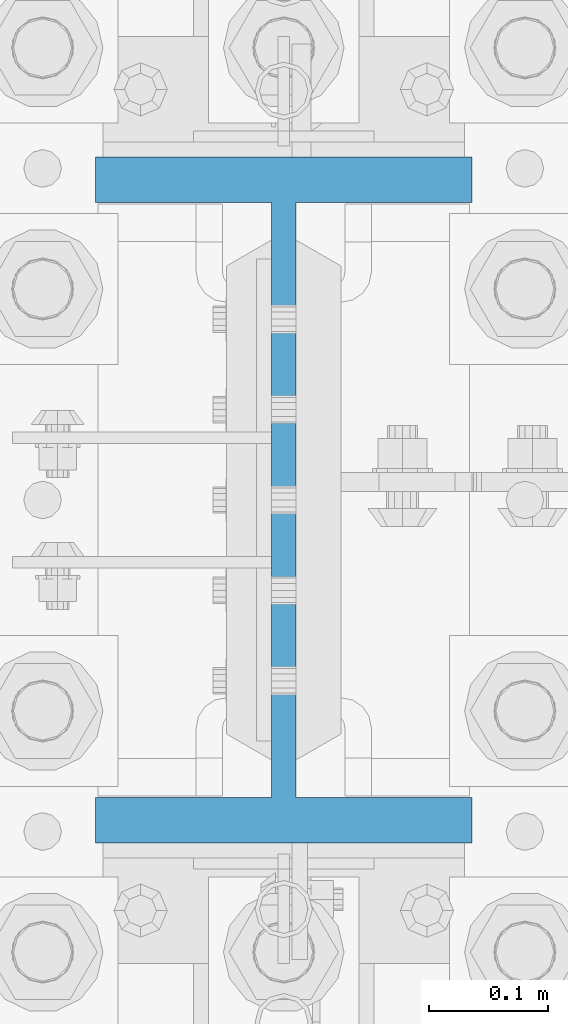
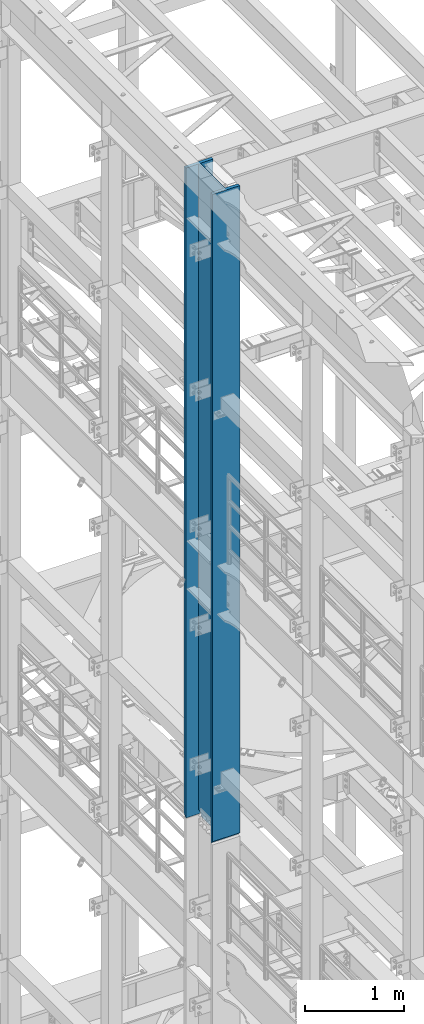
# One storey, part 730 of 1876: 1 column, 1 element without a shape of its own.
"""IFC2X3 building model written with IfcOpenShell, lengths in millimetres."""

from ifc_helpers import new_model, si_unit, frame, origin_with_axes, place, context, subcontext, project, spatial, faceted_brep, material, type_object, element, aggregate, save


model = new_model("IFC2X3")

# Units and contexts
model_context = context("Model", 3, precision=1e-05, world=origin_with_axes())
body_context = subcontext(model_context, "Body", "Model", "MODEL_VIEW")
ifc_project = project(units=[si_unit("LENGTHUNIT", "METRE", prefix="MILLI"), si_unit("AREAUNIT", "SQUARE_METRE"), si_unit("VOLUMEUNIT", "CUBIC_METRE"), si_unit("MASSUNIT", "GRAM", prefix="KILO"), si_unit("TIMEUNIT", "SECOND"), si_unit("PLANEANGLEUNIT", "RADIAN"), si_unit("SOLIDANGLEUNIT", "STERADIAN"), si_unit("THERMODYNAMICTEMPERATUREUNIT", "DEGREE_CELSIUS"), si_unit("LUMINOUSINTENSITYUNIT", "LUMEN")], contexts=[model_context])

# Site, building, storey
site_placement = place(None, origin_with_axes())
site = spatial("IfcSite", under=ifc_project, at=site_placement, CompositionType="ELEMENT")
building_placement = place(site_placement, origin_with_axes())
building = spatial("IfcBuilding", under=site, at=building_placement, Name="Undefined", CompositionType="ELEMENT")
storey_placement = place(building_placement, origin_with_axes())
storey = spatial("IfcBuildingStorey", under=building, at=storey_placement, Name="Undefined", CompositionType="ELEMENT", Elevation=0.0)

# Assembly, column
assembly_placement = place(storey_placement, origin_with_axes())
assembly = element("IfcElementAssembly", 1, at=assembly_placement, inside=storey, Name="COLUMN", AssemblyPlace="NOTDEFINED", PredefinedType="RIGID_FRAME")
ifc_material = material(Name="STEEL/A992")
column_type = type_object("IfcColumnType", Name="W21X182", PredefinedType="NOTDEFINED")
column_placement = place(assembly_placement, frame((0.0, 7620.0, 14528.8), z_axis=(0.0, 1.0, 0.0), x_axis=(0.0, 0.0, 1.0)))
column = element("IfcColumn", 2, at=column_placement, type_object=column_type, material=ifc_material, Name="COLUMN", ObjectType="W21X182", context=body_context, shape_type="Brep", body=[
    faceted_brep([(23.8124996185306, 10.31875, 203.498507902428), (23.8124996185306, 10.31875, -203.49850776611), (6.35000000000036, -7.14374961853027, -200.025000762939), (6.35000000000036, -7.14374961853027, 200.025000762939), (8026.4, 158.75, -288.925), (8026.4, -158.75, -288.925), (41.2749999999833, -158.75, -288.925), (41.2749999999833, 158.75, -288.925), (8026.4, -158.75, -250.825), (57.149999999996, -158.75, -250.825), (6.35000000000036, -158.75, -250.825), (6.35000000000036, -158.75, -254.000000000019), (57.149999999996, -10.3187500000004, -250.825), (6.35000000000036, -10.3187500000004, -250.825), (8026.4, -10.3187500000004, -250.825), (6.35000000000036, -158.75, 250.825), (57.1499992370573, -158.75, 250.825), (8026.4, -158.75, 250.825), (8026.4, -158.75, 288.925), (41.2749999999833, -158.75, 288.925), (6.35000000000036, -158.75, 254.00000000002), (8026.4, 158.75, 288.925), (41.2749999999833, 158.75, 288.925), (6.35000000000036, 158.75, 254.00000000002), (8026.4, 158.75, 250.825), (57.1499992370573, 158.75, 250.825), (6.35000000000036, 158.75, 250.825), (6.35000000000036, -10.3187500000004, 250.825), (6.35000000000036, 10.3187500000004, 250.825), (6.35000000000036, -7.14374961853027, 250.825), (57.1499992370573, -10.3187500000004, 250.825), (8026.4, -10.3187500000004, 250.825), (53.2830795467053, -10.3187500000004, 231.384681927818), (42.2710239447933, -10.3187500000004, 214.903976055203), (25.7903180721787, -10.3187500000004, 203.891920453291), (6.35000000000036, -10.31875, 200.025000762939), (6.35000000000036, -10.31875, -200.025000762939), (25.7903188351174, -10.3187500000004, -203.891920453291), (42.2710247077321, -10.3187500000004, -214.903976055203), (53.283080309644, -10.3187500000004, -231.384681927818), (25.7903188351174, 10.3187500000004, -203.891920453291), (42.2710247077321, 10.3187500000004, -214.903976055203), (53.283080309644, 10.3187500000004, -231.384681927818), (57.1499999999978, 10.3187500000004, -250.825), (57.149999999996, 158.75, -250.825), (6.35000000000036, 158.75, -250.825), (6.35000000000036, 10.3187500000004, -250.825), (23.8124996185306, 10.31875, -250.825), (8026.4, 10.3187500000004, -250.825), (8026.4, 158.75, -250.825), (6.35000000000036, -7.14374961853027, -250.825), (6.35000000000036, 158.75, -254.000000000019), (8026.4, 10.3187500000004, 250.825), (57.1499992370573, 10.3187500000004, 250.825), (23.8124996185306, 10.31875, 250.825), (53.2830795467053, 10.3187500000004, 231.384681927818), (42.2710239447933, 10.3187500000004, 214.903976055203), (25.7903180721787, 10.3187500000004, 203.891920453291)], [[[0, 1, 2, 3]], [[4, 5, 6, 7]], [[5, 8, 9, 10, 11, 6]], [[12, 13, 10, 9, 8, 14]], [[15, 16, 17, 18, 19, 20]], [[18, 21, 22, 19]], [[19, 22, 23, 20]], [[21, 24, 25, 26, 23, 22]], [[27, 15, 20, 23, 26, 28, 29]], [[16, 15, 27, 30, 31, 17]], [[14, 31, 30, 32, 33, 34, 35, 36, 37, 38, 39, 12]], [[37, 40, 41, 38]], [[38, 41, 42, 39]], [[39, 42, 43, 12]], [[44, 45, 46, 47, 43, 48, 49]], [[12, 43, 47, 46, 50, 13]], [[46, 45, 51, 11, 10, 13, 50]], [[6, 11, 51, 7]], [[45, 44, 49, 4, 7, 51]], [[48, 52, 24, 21, 18, 17, 31, 14, 8, 5, 4, 49]], [[53, 54, 28, 26, 25, 24, 52]], [[27, 29, 28, 54, 53, 30]], [[30, 53, 55, 32]], [[32, 55, 56, 33]], [[33, 56, 57, 34]], [[35, 34, 57, 0, 3]], [[36, 35, 3, 2]], [[40, 37, 36, 2, 1]], [[57, 56, 55, 53, 52, 48, 43, 42, 41, 40, 1, 0]]]),
])
aggregate(assembly, [column])

save(model, "model.ifc")
